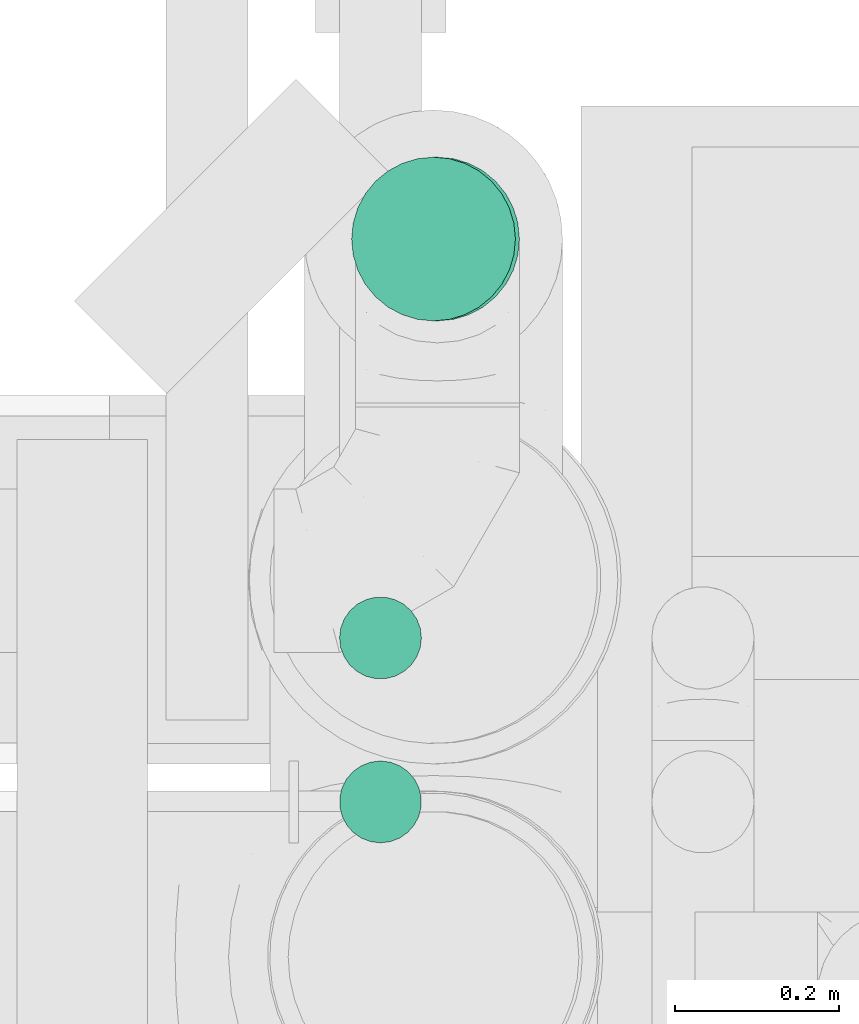
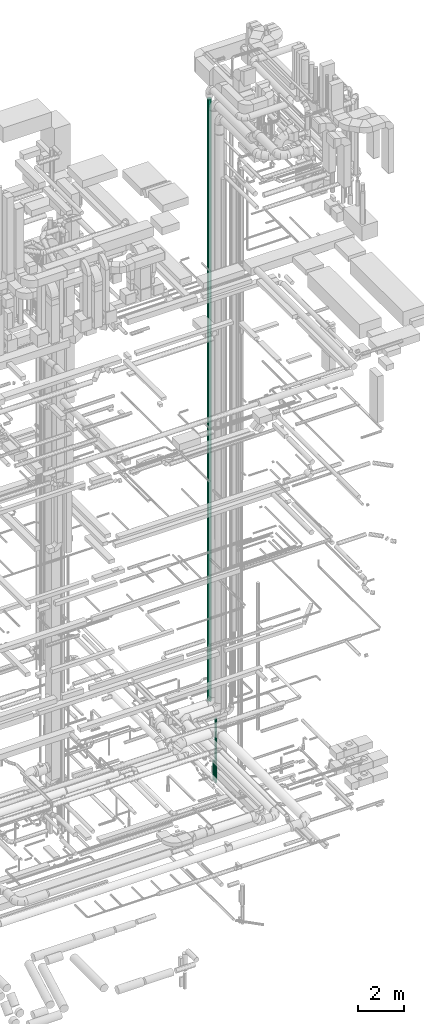
# One storey, part 70 of 337: 3 flow segments.
"""IFC2X3 building model written with IfcOpenShell, lengths in millimetres."""

from ifc_helpers import new_model, entity, si_unit, converted_unit, derived_unit, direction, frame, origin, origin_2d_with_axis, place, context, subcontext, project, spatial, circle, extrude, type_object, element, save


model = new_model("IFC2X3")

# Units and contexts
model_context = context("Model", 3, precision=0.01, world=origin(), true_north=direction((6.12303176911189e-17, 1.0)))
body_context = subcontext(model_context, "Body", "Model", "MODEL_VIEW")
ifc_project = project(units=[si_unit("LENGTHUNIT", "METRE", prefix="MILLI"), si_unit("AREAUNIT", "SQUARE_METRE"), si_unit("VOLUMEUNIT", "CUBIC_METRE"), converted_unit("PLANEANGLEUNIT", "DEGREE", entity("IfcRatioMeasure", 0.0174532925199433), si_unit("PLANEANGLEUNIT", "RADIAN"), dimensions=[0, 0, 0, 0, 0, 0, 0]), si_unit("MASSUNIT", "GRAM", prefix="KILO"), derived_unit("MASSDENSITYUNIT", [(si_unit("MASSUNIT", "GRAM", prefix="KILO"), 1), (si_unit("LENGTHUNIT", "METRE"), -3)]), derived_unit("MOMENTOFINERTIAUNIT", [(si_unit("LENGTHUNIT", "METRE"), 4)]), si_unit("TIMEUNIT", "SECOND"), si_unit("FREQUENCYUNIT", "HERTZ"), si_unit("THERMODYNAMICTEMPERATUREUNIT", "DEGREE_CELSIUS"), derived_unit("THERMALTRANSMITTANCEUNIT", [(si_unit("MASSUNIT", "GRAM", prefix="KILO"), 1), (si_unit("THERMODYNAMICTEMPERATUREUNIT", "KELVIN"), -1), (si_unit("TIMEUNIT", "SECOND"), -3)]), derived_unit("VOLUMETRICFLOWRATEUNIT", [(si_unit("LENGTHUNIT", "METRE"), 3), (si_unit("TIMEUNIT", "SECOND"), -1)]), derived_unit("MASSFLOWRATEUNIT", [(si_unit("MASSUNIT", "GRAM", prefix="KILO"), 1), (si_unit("TIMEUNIT", "SECOND"), -1)]), derived_unit("ROTATIONALFREQUENCYUNIT", [(si_unit("TIMEUNIT", "SECOND"), -1)]), si_unit("ELECTRICCURRENTUNIT", "AMPERE"), si_unit("ELECTRICVOLTAGEUNIT", "VOLT"), si_unit("POWERUNIT", "WATT"), si_unit("FORCEUNIT", "NEWTON", prefix="KILO"), si_unit("ILLUMINANCEUNIT", "LUX"), si_unit("LUMINOUSFLUXUNIT", "LUMEN"), si_unit("LUMINOUSINTENSITYUNIT", "CANDELA"), derived_unit("USERDEFINED", [(si_unit("MASSUNIT", "GRAM", prefix="KILO"), -1), (si_unit("LENGTHUNIT", "METRE"), -2), (si_unit("TIMEUNIT", "SECOND"), 3), (si_unit("LUMINOUSFLUXUNIT", "LUMEN"), 1)]), derived_unit("LINEARVELOCITYUNIT", [(si_unit("LENGTHUNIT", "METRE"), 1), (si_unit("TIMEUNIT", "SECOND"), -1)]), si_unit("PRESSUREUNIT", "PASCAL"), derived_unit("USERDEFINED", [(si_unit("LENGTHUNIT", "METRE"), -2), (si_unit("MASSUNIT", "GRAM", prefix="KILO"), 1), (si_unit("TIMEUNIT", "SECOND"), -2)]), derived_unit("LINEARFORCEUNIT", [(si_unit("MASSUNIT", "GRAM", prefix="KILO"), 1), (si_unit("LENGTHUNIT", "METRE"), 1), (si_unit("TIMEUNIT", "SECOND"), -2), (si_unit("LENGTHUNIT", "METRE"), -1)]), derived_unit("PLANARFORCEUNIT", [(si_unit("MASSUNIT", "GRAM", prefix="KILO"), 1), (si_unit("LENGTHUNIT", "METRE"), 1), (si_unit("TIMEUNIT", "SECOND"), -2), (si_unit("LENGTHUNIT", "METRE"), -2)])], contexts=[model_context])

# Site, building, storey
site_placement = place(None, origin())
site = spatial("IfcSite", under=ifc_project, at=site_placement, CompositionType="ELEMENT")
building_placement = place(site_placement, origin())
building = spatial("IfcBuilding", under=site, at=building_placement, CompositionType="ELEMENT")
storey_placement = place(building_placement, origin())
storey = spatial("IfcBuildingStorey", under=building, at=storey_placement, CompositionType="ELEMENT", Elevation=0.0)

# Flow segments
duct_segment_type = type_object("IfcDuctSegmentType", PredefinedType="NOTDEFINED")
flow_segment_1_placement = place(storey_placement, frame((67442.66, 11926.94, -1010.0)))
element("IfcFlowSegment", 1, at=flow_segment_1_placement, inside=storey, type_object=duct_segment_type, context=body_context, shape_type="SweptSolid", body=[
    extrude(circle(Radius=50.0, at=origin_2d_with_axis()), frame((51.6, 51.6, 0.0), z_axis=(0.0, 0.0, 1.0), x_axis=(0.0, -1.0, 0.0)), (0.0, 0.0, 1.0), 3410.00000000001),
])
flow_segment_2_placement = place(storey_placement, frame((67442.66, 12127.14, -1012.34)))
element("IfcFlowSegment", 2, at=flow_segment_2_placement, inside=storey, type_object=duct_segment_type, context=body_context, shape_type="SweptSolid", body=[
    extrude(circle(Radius=50.0, at=origin_2d_with_axis()), frame((51.6, 51.6, 0.0), z_axis=(0.0, 0.0, 1.0), x_axis=(-1.0, 0.0, 0.0)), (0.0, 0.0, 1.0), 1040.0),
])
flow_segment_3_placement = place(storey_placement, frame((67457.44, 12564.21, 2899.98)))
element("IfcFlowSegment", 3, at=flow_segment_3_placement, inside=storey, type_object=duct_segment_type, context=body_context, shape_type="SweptSolid", body=[
    extrude(circle(Radius=100.0, at=origin_2d_with_axis()), frame((106.5, 101.6, 0.02), z_axis=(-0.000153370840218213, 0.0, 0.999999988238693), x_axis=(-0.999999988238693, 0.0, -0.000153370840218213)), (0.0, 0.0, 1.0), 31990.2069018321),
])

save(model, "model.ifc")
